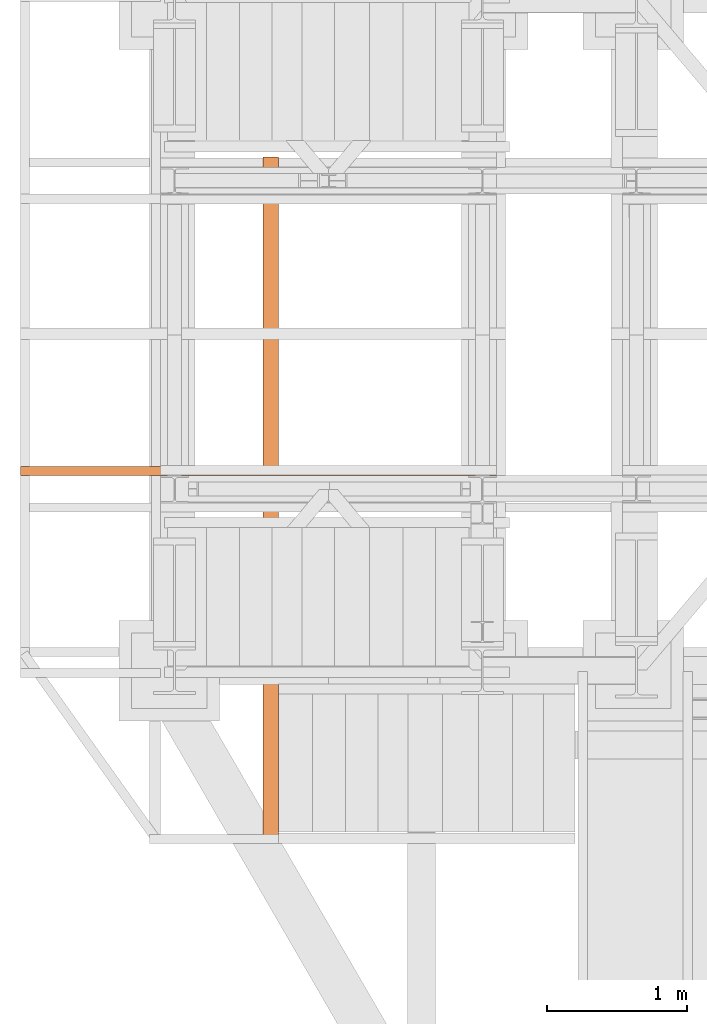
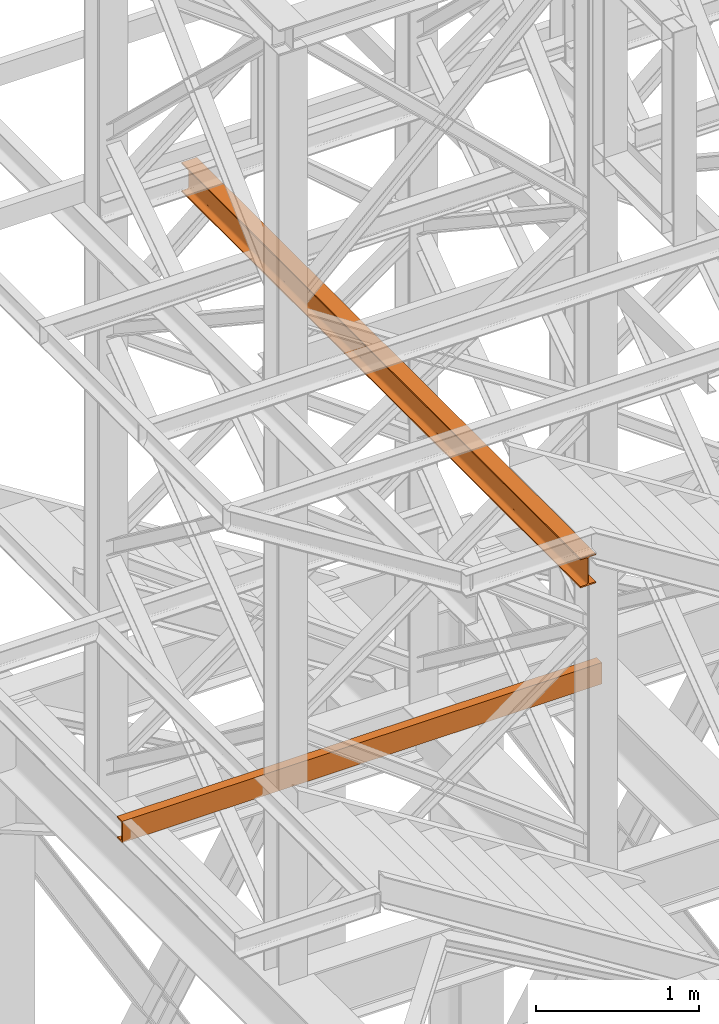
# One storey, part 84 of 208: 2 proxies.
"""IFC2X3 building model written with IfcOpenShell, lengths in millimetres."""

from ifc_helpers import new_model, entity, si_unit, converted_unit, frame, origin, origin_with_axes, place, context, subcontext, project, spatial, faceted_brep, element, save


model = new_model("IFC2X3")

# Units and contexts
model_context = context("Model", 3, precision=1e-05, world=origin())
plan_context = context("Plan", 3, precision=1e-05, world=origin())
body_context = subcontext(model_context, "Body", "Model", "MODEL_VIEW")
ifc_project = project(units=[si_unit("LENGTHUNIT", "METRE", prefix="MILLI"), converted_unit("PLANEANGLEUNIT", "DEGREE", entity("IfcPlaneAngleMeasure", 0.0174532925199433), si_unit("PLANEANGLEUNIT", "RADIAN"), dimensions=[0, 0, 0, 0, 0, 0, 0]), si_unit("AREAUNIT", "SQUARE_METRE"), si_unit("VOLUMEUNIT", "CUBIC_METRE")], contexts=[model_context, plan_context])

# Building, storey
building_placement = place(None, origin())
building = spatial("IfcBuilding", under=ifc_project, at=building_placement, CompositionType="COMPLEX")
storey_placement = place(building_placement, origin_with_axes())
storey = spatial("IfcBuildingStorey", under=building, at=storey_placement, Name="Geschoss", CompositionType="ELEMENT")

# Proxies
proxy_1_placement = place(storey_placement, frame((-4406.745032961457, -15867.5743840594, 6584.990005364416), z_axis=(0.0, 0.0, 1.0), x_axis=(1.0, 0.0, 0.0)))
element("IfcBuildingElementProxy", 1, at=proxy_1_placement, inside=storey, context=body_context, shape_type="Brep", body=[
    faceted_brep([(0.01000000000021828, 65.01000000000022, 0.01000000000021828), (3400.010002980236, 65.01000000000022, 0.01000000000021828), (3400.010002980236, 65.01000000000022, 3.132428070246533), (0.01000000000021828, 65.01000000000022, 3.132428070246533), (0.01000000000021828, 65.01000000000022, 3.132428070246533), (3400.010002980236, 65.01000000000022, 3.132428070246533), (3400.010002980236, 64.76726342282745, 4.748288908171162), (0.01000000000021828, 64.76726342282745, 4.748288908171162), (0.01000000000021828, 64.76726342282745, 4.748288908171162), (3400.010002980236, 64.76726342282745, 4.748288908171162), (3400.010002980236, 64.06053228585552, 6.221534443444398), (0.01000000000021828, 64.06053228585733, 6.221534443444398), (0.01000000000021828, 64.06053228585733, 6.221534443444398), (3400.010002980236, 64.06053228585552, 6.221534443444398), (3400.010002980236, 62.95215163846842, 7.422126703873801), (0.01000000000021828, 62.95215163847024, 7.422126703873801), (0.01000000000021828, 62.95215163847024, 7.422126703873801), (3400.010002980236, 62.95215163846842, 7.422126703873801), (3400.010002980236, 61.53995641148504, 8.244091391710754), (0.01000000000021828, 61.53995641148504, 8.244091391710754), (0.01000000000021828, 61.53995641148504, 8.244091391710754), (3400.010002980236, 61.53995641148504, 8.244091391710754), (3400.010002980236, 59.9485987225562, 8.614912102195376), (0.01000000000021828, 59.9485987225562, 8.614912102195376), (0.01000000000021828, 59.9485987225562, 8.614912102195376), (3400.010002980236, 59.9485987225562, 8.614912102195376), (3400.010002980236, 17.17267516602988, 12.0369859867169), (0.01000000000021828, 17.17267516602988, 12.0369859867169), (0.01000000000021828, 17.17267516602988, 12.0369859867169), (3400.010002980236, 17.17267516602988, 12.0369859867169), (3400.010002980236, 14.13462866898408, 12.74491643400506), (0.01000000000021828, 14.13462866898408, 12.74491643400506), (0.01000000000021828, 14.13462866898408, 12.74491643400506), (3400.010002980236, 14.13462866898408, 12.74491643400506), (3400.010002980236, 11.43861959928654, 14.31412174714933), (0.01000000000021828, 11.43861959928654, 14.31412174714933), (0.01000000000021828, 11.43861959928654, 14.31412174714933), (3400.010002980236, 11.43861959928654, 14.31412174714933), (3400.010002980236, 9.322620181546881, 16.60616151705835), (0.01000000000021828, 9.322620181546881, 16.60616151705835), (0.01000000000021828, 9.322620181546881, 16.60616151705835), (3400.010002980236, 9.322620181546881, 16.60616151705835), (3400.010002980236, 7.97340619278657, 19.41872117530875), (0.01000000000021828, 7.97340619278657, 19.41872117530875), (0.01000000000021828, 7.97340619278657, 19.41872117530875), (3400.010002980236, 7.97340619278657, 19.41872117530875), (3400.010002980236, 7.510000000000218, 22.50354641134618), (0.01000000000021828, 7.510000000000218, 22.50354641134618), (0.01000000000021828, 7.510000000000218, 22.50354641134618), (3400.010002980236, 7.510000000000218, 22.50354641134618), (3400.010002980236, 7.510000000000218, 137.5164535886524), (0.01000000000021828, 7.510000000000218, 137.5164535886524), (0.01000000000021828, 7.510000000000218, 137.5164535886524), (3400.010002980236, 7.510000000000218, 137.5164535886524), (3400.010002980236, 7.97340619278657, 140.6012788246917), (0.01000000000021828, 7.97340619278657, 140.6012788246917), (0.01000000000021828, 7.97340619278657, 140.6012788246917), (3400.010002980236, 7.97340619278657, 140.6012788246917), (3400.010002980236, 9.322620181546881, 143.4138384829403), (0.01000000000021828, 9.322620181546881, 143.4138384829403), (0.01000000000021828, 9.322620181546881, 143.4138384829403), (3400.010002980236, 9.322620181546881, 143.4138384829403), (3400.010002980236, 11.43861959928654, 145.7058782528493), (0.01000000000021828, 11.43861959928654, 145.7058782528493), (0.01000000000021828, 11.43861959928654, 145.7058782528493), (3400.010002980236, 11.43861959928654, 145.7058782528493), (3400.010002980236, 14.13462866898408, 147.2750835659936), (0.01000000000021828, 14.13462866898408, 147.2750835659936), (0.01000000000021828, 14.13462866898408, 147.2750835659936), (3400.010002980236, 14.13462866898408, 147.2750835659936), (3400.010002980236, 17.17267516602988, 147.9830140132817), (0.01000000000021828, 17.17267516602988, 147.9830140132817), (0.01000000000021828, 17.17267516602988, 147.9830140132817), (3400.010002980236, 17.17267516602988, 147.9830140132817), (3400.010002980236, 59.9485987225562, 151.4050878978032), (0.01000000000021828, 59.9485987225562, 151.4050878978032), (0.01000000000021828, 59.9485987225562, 151.4050878978032), (3400.010002980236, 59.9485987225562, 151.4050878978032), (3400.010002980236, 61.53995641148504, 151.7759086082879), (0.01000000000021828, 61.53995641148504, 151.7759086082879), (0.01000000000021828, 61.53995641148504, 151.7759086082879), (3400.010002980236, 61.53995641148504, 151.7759086082879), (3400.010002980236, 62.95215163846842, 152.5978732961248), (0.01000000000021828, 62.95215163847024, 152.5978732961248), (0.01000000000021828, 62.95215163847024, 152.5978732961248), (3400.010002980236, 62.95215163846842, 152.5978732961248), (3400.010002980236, 64.06053228585552, 153.7984655565542), (0.01000000000021828, 64.06053228585733, 153.7984655565542), (0.01000000000021828, 64.06053228585733, 153.7984655565542), (3400.010002980236, 64.06053228585552, 153.7984655565542), (3400.010002980236, 64.76726342282745, 155.2717110918275), (0.01000000000021828, 64.76726342282745, 155.2717110918275), (0.01000000000021828, 64.76726342282745, 155.2717110918275), (3400.010002980236, 64.76726342282745, 155.2717110918275), (3400.010002980236, 65.01000000000022, 156.8875719297521), (0.01000000000021828, 65.01000000000022, 156.8875719297521), (0.01000000000021828, 65.01000000000022, 156.8875719297521), (3400.010002980236, 65.01000000000022, 156.8875719297521), (3400.010002980236, 65.01000000000022, 160.0100000000002), (0.01000000000021828, 65.01000000000022, 160.0100000000002), (0.01000000000021828, 65.01000000000022, 160.0100000000002), (3400.010002980236, 65.01000000000022, 160.0100000000002), (3400.010002980236, 0.01000000000021828, 160.0100000000002), (0.01000000000021828, 0.01000000000021828, 160.0100000000002), (0.01000000000021828, 0.01000000000021828, 160.0100000000002), (3400.010002980236, 0.01000000000021828, 160.0100000000002), (3400.010002980236, 0.01000000000021828, 0.01000000000021828), (0.01000000000021828, 0.01000000000021828, 0.01000000000021828), (0.01000000000021828, 0.01000000000021828, 0.01000000000021828), (3400.010002980236, 0.01000000000021828, 0.01000000000021828), (3400.010002980236, 65.01000000000022, 0.01000000000021828), (0.01000000000021828, 65.01000000000022, 0.01000000000021828), (0.01000000000021828, 65.01000000000022, 0.01000000000021828), (0.01000000000021828, 65.01000000000022, 3.132428070246533), (0.01000000000021828, 64.76726342282745, 4.748288908171162), (0.01000000000021828, 64.06053228585733, 6.221534443444398), (0.01000000000021828, 62.95215163847024, 7.422126703873801), (0.01000000000021828, 61.53995641148504, 8.244091391710754), (0.01000000000021828, 59.9485987225562, 8.614912102195376), (0.01000000000021828, 17.17267516602988, 12.0369859867169), (0.01000000000021828, 14.13462866898408, 12.74491643400506), (0.01000000000021828, 11.43861959928654, 14.31412174714933), (0.01000000000021828, 9.322620181546881, 16.60616151705835), (0.01000000000021828, 7.97340619278657, 19.41872117530875), (0.01000000000021828, 7.510000000000218, 22.50354641134618), (0.01000000000021828, 7.510000000000218, 137.5164535886524), (0.01000000000021828, 7.97340619278657, 140.6012788246917), (0.01000000000021828, 9.322620181546881, 143.4138384829403), (0.01000000000021828, 11.43861959928654, 145.7058782528493), (0.01000000000021828, 14.13462866898408, 147.2750835659936), (0.01000000000021828, 17.17267516602988, 147.9830140132817), (0.01000000000021828, 59.9485987225562, 151.4050878978032), (0.01000000000021828, 61.53995641148504, 151.7759086082879), (0.01000000000021828, 62.95215163847024, 152.5978732961248), (0.01000000000021828, 64.06053228585733, 153.7984655565542), (0.01000000000021828, 64.76726342282745, 155.2717110918275), (0.01000000000021828, 65.01000000000022, 156.8875719297521), (0.01000000000021828, 65.01000000000022, 160.0100000000002), (0.01000000000021828, 0.01000000000021828, 160.0100000000002), (0.01000000000021828, 0.01000000000021828, 0.01000000000021828), (3400.010002980236, 65.01000000000022, 0.01000000000021828), (3400.010002980236, 0.01000000000021828, 0.01000000000021828), (3400.010002980236, 0.01000000000021828, 160.0100000000002), (3400.010002980236, 65.01000000000022, 160.0100000000002), (3400.010002980236, 65.01000000000022, 156.8875719297521), (3400.010002980236, 64.76726342282745, 155.2717110918275), (3400.010002980236, 64.06053228585552, 153.7984655565542), (3400.010002980236, 62.95215163846842, 152.5978732961248), (3400.010002980236, 61.53995641148504, 151.7759086082879), (3400.010002980236, 59.9485987225562, 151.4050878978032), (3400.010002980236, 17.17267516602988, 147.9830140132817), (3400.010002980236, 14.13462866898408, 147.2750835659936), (3400.010002980236, 11.43861959928654, 145.7058782528493), (3400.010002980236, 9.322620181546881, 143.4138384829403), (3400.010002980236, 7.97340619278657, 140.6012788246917), (3400.010002980236, 7.510000000000218, 137.5164535886524), (3400.010002980236, 7.510000000000218, 22.50354641134618), (3400.010002980236, 7.97340619278657, 19.41872117530875), (3400.010002980236, 9.322620181546881, 16.60616151705835), (3400.010002980236, 11.43861959928654, 14.31412174714933), (3400.010002980236, 14.13462866898408, 12.74491643400506), (3400.010002980236, 17.17267516602988, 12.0369859867169), (3400.010002980236, 59.9485987225562, 8.614912102195376), (3400.010002980236, 61.53995641148504, 8.244091391710754), (3400.010002980236, 62.95215163846842, 7.422126703873801), (3400.010002980236, 64.06053228585552, 6.221534443444398), (3400.010002980236, 64.76726342282745, 4.748288908171162), (3400.010002980236, 65.01000000000022, 3.132428070246533)], [[[0, 1, 2, 3]], [[4, 5, 6, 7]], [[8, 9, 10, 11]], [[12, 13, 14, 15]], [[16, 17, 18, 19]], [[20, 21, 22, 23]], [[24, 25, 26, 27]], [[28, 29, 30, 31]], [[32, 33, 34, 35]], [[36, 37, 38, 39]], [[40, 41, 42, 43]], [[44, 45, 46, 47]], [[48, 49, 50, 51]], [[52, 53, 54, 55]], [[56, 57, 58, 59]], [[60, 61, 62, 63]], [[64, 65, 66, 67]], [[68, 69, 70, 71]], [[72, 73, 74, 75]], [[76, 77, 78, 79]], [[80, 81, 82, 83]], [[84, 85, 86, 87]], [[88, 89, 90, 91]], [[92, 93, 94, 95]], [[96, 97, 98, 99]], [[100, 101, 102, 103]], [[104, 105, 106, 107]], [[108, 109, 110, 111]], [[112, 113, 114, 115, 116, 117, 118, 119, 120, 121, 122, 123, 124, 125, 126, 127, 128, 129, 130, 131, 132, 133, 134, 135, 136, 137, 138, 139]], [[140, 141, 142, 143, 144, 145, 146, 147, 148, 149, 150, 151, 152, 153, 154, 155, 156, 157, 158, 159, 160, 161, 162, 163, 164, 165, 166, 167]]], orient=[[False], [False], [False], [False], [False], [False], [False], [False], [False], [False], [False], [False], [False], [False], [False], [False], [False], [False], [False], [False], [False], [False], [False], [False], [False], [False], [False], [False], [False], [False]]),
])
proxy_2_placement = place(storey_placement, frame((-2673.970189809399, -18492.51299053056, 9479.99), z_axis=(0.0, 0.0, 1.0), x_axis=(1.0, 0.0, 0.0)))
element("IfcBuildingElementProxy", 2, at=proxy_2_placement, inside=storey, Name="3D Element", context=body_context, shape_type="Brep", body=[
    faceted_brep([(0.01000000000021828, 4900.010002980234, 9.209999809265355), (0.01000000000021828, 4900.010002980234, 0.01000000000021828), (110.0100000000002, 4900.010002980234, 0.01000000000021828), (110.0100000000002, 4900.010002980234, 9.209999809265355), (70.57913068098969, 4900.010002980234, 9.209999809265355), (66.251808693969, 4900.010002980234, 9.797362501594762), (62.90658890732811, 4900.010002980234, 11.50181071442057), (60.25181095283915, 4900.010002980234, 14.15658866890954), (58.54736274001334, 4900.010002980234, 17.50180845555042), (57.96000004768393, 4900.010002980234, 21.20999980926536), (57.96000004768393, 4900.010002980234, 198.8100001907351), (58.36892529768193, 4900.010002980234, 201.915818315525), (59.56772743354668, 4900.010002980234, 204.8099826905327), (61.47471867344575, 4900.010002980234, 207.2952815649733), (63.96001754788813, 4900.010002980234, 209.2022728048742), (66.85418192289399, 4900.010002980234, 210.4010749407371), (69.96000004768393, 4900.010002980234, 210.8100001907351), (110.0100000000002, 4900.010002980234, 210.8100001907351), (110.0100000000002, 4900.010002980234, 220.0100000000002), (0.01000000000021828, 4900.010002980234, 220.0100000000002), (0.01000000000021828, 4900.010002980234, 210.8100001907351), (40.0599999523165, 4900.010002980234, 210.8100001907351), (43.16581807710645, 4900.010002980234, 210.4010749407371), (46.05998245211413, 4900.010002980234, 209.2022728048742), (48.54528132655469, 4900.010002980234, 207.2952815649733), (50.52982171082658, 4900.010002980234, 204.6227624944386), (51.65107470232033, 4900.010002980234, 201.915818315525), (52.0599999523165, 4900.010002980234, 198.8100001907351), (52.0599999523165, 4900.010002980234, 21.20999980926536), (51.65107470232033, 4900.010002980234, 18.10418168447541), (50.45227256645558, 4900.010002980234, 15.21001730946955), (48.54528132655469, 4900.010002980234, 12.72471843502717), (46.05998245211413, 4900.010002980234, 10.81772719512628), (43.16581807710645, 4900.010002980234, 9.618925059263347), (40.0599999523165, 4900.010002980234, 9.209999809265355), (0.01000000000021828, 4900.010002980234, 0.01000000000021828), (0.01000000000021828, 4900.010002980234, 9.209999809265355), (0.01000000000021828, 0.00999999999839929, 9.209999809265355), (0.01000000000021828, 0.00999999999839929, 0.01000000000021828), (110.0100000000002, 4900.010002980234, 0.01000000000021828), (0.01000000000021828, 4900.010002980234, 0.01000000000021828), (0.01000000000021828, 0.00999999999839929, 0.01000000000021828), (110.0100000000002, 0.00999999999839929, 0.01000000000021828), (110.0100000000002, 4900.010002980234, 9.209999809265355), (110.0100000000002, 4900.010002980234, 0.01000000000021828), (110.0100000000002, 0.00999999999839929, 0.01000000000021828), (110.0100000000002, 0.00999999999839929, 9.209999809265355), (70.57913068098969, 4900.010002980234, 9.209999809265355), (110.0100000000002, 4900.010002980234, 9.209999809265355), (110.0100000000002, 0.00999999999839929, 9.209999809265355), (70.57913068098969, 0.00999999999839929, 9.209999809265355), (66.251808693969, 4900.010002980234, 9.797362501594762), (70.57913068098969, 4900.010002980234, 9.209999809265355), (70.57913068098969, 0.00999999999839929, 9.209999809265355), (66.251808693969, 0.00999999999839929, 9.797362501594762), (62.90658890732811, 4900.010002980234, 11.50181071442057), (66.251808693969, 4900.010002980234, 9.797362501594762), (66.251808693969, 0.00999999999839929, 9.797362501594762), (62.90658890732811, 0.00999999999839929, 11.50181071442057), (60.25181095283915, 4900.010002980234, 14.15658866890954), (62.90658890732811, 4900.010002980234, 11.50181071442057), (62.90658890732811, 0.00999999999839929, 11.50181071442057), (60.25181095283915, 0.00999999999839929, 14.15658866890954), (58.54736274001334, 4900.010002980234, 17.50180845555042), (60.25181095283915, 4900.010002980234, 14.15658866890954), (60.25181095283915, 0.00999999999839929, 14.15658866890954), (58.54736274001334, 0.00999999999839929, 17.50180845555042), (57.96000004768393, 4900.010002980234, 21.20999980926536), (58.54736274001334, 4900.010002980234, 17.50180845555042), (58.54736274001334, 0.00999999999839929, 17.50180845555042), (57.96000004768393, 0.00999999999839929, 21.20999980926536), (57.96000004768393, 4900.010002980234, 198.8100001907351), (57.96000004768393, 4900.010002980234, 21.20999980926536), (57.96000004768393, 0.00999999999839929, 21.20999980926536), (57.96000004768393, 0.00999999999839929, 198.8100001907351), (58.36892529768193, 4900.010002980234, 201.915818315525), (57.96000004768393, 4900.010002980234, 198.8100001907351), (57.96000004768393, 0.00999999999839929, 198.8100001907351), (58.36892529768193, 0.00999999999839929, 201.915818315525), (59.56772743354668, 4900.010002980234, 204.8099826905327), (58.36892529768193, 4900.010002980234, 201.915818315525), (58.36892529768193, 0.00999999999839929, 201.915818315525), (59.56772743354668, 0.00999999999839929, 204.8099826905327), (61.47471867344575, 4900.010002980234, 207.2952815649733), (59.56772743354668, 4900.010002980234, 204.8099826905327), (59.56772743354668, 0.00999999999839929, 204.8099826905327), (61.47471867344575, 0.00999999999839929, 207.2952815649733), (63.96001754788813, 4900.010002980234, 209.2022728048742), (61.47471867344575, 4900.010002980234, 207.2952815649733), (61.47471867344575, 0.00999999999839929, 207.2952815649733), (63.96001754788813, 0.00999999999839929, 209.2022728048742), (66.85418192289399, 4900.010002980234, 210.4010749407371), (63.96001754788813, 4900.010002980234, 209.2022728048742), (63.96001754788813, 0.00999999999839929, 209.2022728048742), (66.85418192289399, 0.00999999999839929, 210.4010749407371), (69.96000004768393, 4900.010002980234, 210.8100001907351), (66.85418192289399, 4900.010002980234, 210.4010749407371), (66.85418192289399, 0.00999999999839929, 210.4010749407371), (69.96000004768393, 0.00999999999839929, 210.8100001907351), (110.0100000000002, 4900.010002980234, 210.8100001907351), (69.96000004768393, 4900.010002980234, 210.8100001907351), (69.96000004768393, 0.00999999999839929, 210.8100001907351), (110.0100000000002, 0.00999999999839929, 210.8100001907351), (110.0100000000002, 4900.010002980234, 220.0100000000002), (110.0100000000002, 4900.010002980234, 210.8100001907351), (110.0100000000002, 0.00999999999839929, 210.8100001907351), (110.0100000000002, 0.00999999999839929, 220.0100000000002), (0.01000000000021828, 4900.010002980234, 220.0100000000002), (110.0100000000002, 4900.010002980234, 220.0100000000002), (110.0100000000002, 0.00999999999839929, 220.0100000000002), (0.01000000000021828, 0.00999999999839929, 220.0100000000002), (0.01000000000021828, 4900.010002980234, 210.8100001907351), (0.01000000000021828, 4900.010002980234, 220.0100000000002), (0.01000000000021828, 0.00999999999839929, 220.0100000000002), (0.01000000000021828, 0.00999999999839929, 210.8100001907351), (40.0599999523165, 4900.010002980234, 210.8100001907351), (0.01000000000021828, 4900.010002980234, 210.8100001907351), (0.01000000000021828, 0.00999999999839929, 210.8100001907351), (40.0599999523165, 0.00999999999839929, 210.8100001907351), (43.16581807710645, 4900.010002980234, 210.4010749407371), (40.0599999523165, 4900.010002980234, 210.8100001907351), (40.0599999523165, 0.00999999999839929, 210.8100001907351), (43.16581807710645, 0.00999999999839929, 210.4010749407371), (46.05998245211413, 4900.010002980234, 209.2022728048742), (43.16581807710645, 4900.010002980234, 210.4010749407371), (43.16581807710645, 0.00999999999839929, 210.4010749407371), (46.05998245211413, 0.00999999999839929, 209.2022728048742), (48.54528132655469, 4900.010002980234, 207.2952815649733), (46.05998245211413, 4900.010002980234, 209.2022728048742), (46.05998245211413, 0.00999999999839929, 209.2022728048742), (48.54528132655469, 0.00999999999839929, 207.2952815649733), (50.52982171082658, 4900.010002980234, 204.6227624944386), (48.54528132655469, 4900.010002980234, 207.2952815649733), (48.54528132655469, 0.00999999999839929, 207.2952815649733), (50.52982171082658, 0.00999999999839929, 204.6227624944386), (51.65107470232033, 4900.010002980234, 201.915818315525), (50.52982171082658, 4900.010002980234, 204.6227624944386), (50.52982171082658, 0.00999999999839929, 204.6227624944386), (51.65107470232033, 0.00999999999839929, 201.915818315525), (52.0599999523165, 4900.010002980234, 198.8100001907351), (51.65107470232033, 4900.010002980234, 201.915818315525), (51.65107470232033, 0.00999999999839929, 201.915818315525), (52.0599999523165, 0.00999999999839929, 198.8100001907351), (52.0599999523165, 4900.010002980234, 21.20999980926536), (52.0599999523165, 4900.010002980234, 198.8100001907351), (52.0599999523165, 0.00999999999839929, 198.8100001907351), (52.0599999523165, 0.00999999999839929, 21.20999980926536), (51.65107470232033, 4900.010002980234, 18.10418168447541), (52.0599999523165, 4900.010002980234, 21.20999980926536), (52.0599999523165, 0.00999999999839929, 21.20999980926536), (51.65107470232033, 0.00999999999839929, 18.10418168447541), (50.45227256645558, 4900.010002980234, 15.21001730946955), (51.65107470232033, 4900.010002980234, 18.10418168447541), (51.65107470232033, 0.00999999999839929, 18.10418168447541), (50.45227256645558, 0.00999999999839929, 15.21001730946955), (48.54528132655469, 4900.010002980234, 12.72471843502717), (50.45227256645558, 4900.010002980234, 15.21001730946955), (50.45227256645558, 0.00999999999839929, 15.21001730946955), (48.54528132655469, 0.00999999999839929, 12.72471843502717), (46.05998245211413, 4900.010002980234, 10.81772719512628), (48.54528132655469, 4900.010002980234, 12.72471843502717), (48.54528132655469, 0.00999999999839929, 12.72471843502717), (46.05998245211413, 0.00999999999839929, 10.81772719512628), (43.16581807710645, 4900.010002980234, 9.618925059263347), (46.05998245211413, 4900.010002980234, 10.81772719512628), (46.05998245211413, 0.00999999999839929, 10.81772719512628), (43.16581807710645, 0.00999999999839929, 9.618925059263347), (40.0599999523165, 4900.010002980234, 9.209999809265355), (43.16581807710645, 4900.010002980234, 9.618925059263347), (43.16581807710645, 0.00999999999839929, 9.618925059263347), (40.0599999523165, 0.00999999999839929, 9.209999809265355), (0.01000000000021828, 4900.010002980234, 9.209999809265355), (40.0599999523165, 4900.010002980234, 9.209999809265355), (40.0599999523165, 0.00999999999839929, 9.209999809265355), (0.01000000000021828, 0.00999999999839929, 9.209999809265355), (0.01000000000021828, 0.00999999999839929, 9.209999809265355), (40.0599999523165, 0.00999999999839929, 9.209999809265355), (43.16581807710645, 0.00999999999839929, 9.618925059263347), (46.05998245211413, 0.00999999999839929, 10.81772719512628), (48.54528132655469, 0.00999999999839929, 12.72471843502717), (50.45227256645558, 0.00999999999839929, 15.21001730946955), (51.65107470232033, 0.00999999999839929, 18.10418168447541), (52.0599999523165, 0.00999999999839929, 21.20999980926536), (52.0599999523165, 0.00999999999839929, 198.8100001907351), (51.65107470232033, 0.00999999999839929, 201.915818315525), (50.52982171082658, 0.00999999999839929, 204.6227624944386), (48.54528132655469, 0.00999999999839929, 207.2952815649733), (46.05998245211413, 0.00999999999839929, 209.2022728048742), (43.16581807710645, 0.00999999999839929, 210.4010749407371), (40.0599999523165, 0.00999999999839929, 210.8100001907351), (0.01000000000021828, 0.00999999999839929, 210.8100001907351), (0.01000000000021828, 0.00999999999839929, 220.0100000000002), (110.0100000000002, 0.00999999999839929, 220.0100000000002), (110.0100000000002, 0.00999999999839929, 210.8100001907351), (69.96000004768393, 0.00999999999839929, 210.8100001907351), (66.85418192289399, 0.00999999999839929, 210.4010749407371), (63.96001754788813, 0.00999999999839929, 209.2022728048742), (61.47471867344575, 0.00999999999839929, 207.2952815649733), (59.56772743354668, 0.00999999999839929, 204.8099826905327), (58.36892529768193, 0.00999999999839929, 201.915818315525), (57.96000004768393, 0.00999999999839929, 198.8100001907351), (57.96000004768393, 0.00999999999839929, 21.20999980926536), (58.54736274001334, 0.00999999999839929, 17.50180845555042), (60.25181095283915, 0.00999999999839929, 14.15658866890954), (62.90658890732811, 0.00999999999839929, 11.50181071442057), (66.251808693969, 0.00999999999839929, 9.797362501594762), (70.57913068098969, 0.00999999999839929, 9.209999809265355), (110.0100000000002, 0.00999999999839929, 9.209999809265355), (110.0100000000002, 0.00999999999839929, 0.01000000000021828), (0.01000000000021828, 0.00999999999839929, 0.01000000000021828)], [[[0, 1, 2, 3, 4, 5, 6, 7, 8, 9, 10, 11, 12, 13, 14, 15, 16, 17, 18, 19, 20, 21, 22, 23, 24, 25, 26, 27, 28, 29, 30, 31, 32, 33, 34]], [[35, 36, 37, 38]], [[39, 40, 41, 42]], [[43, 44, 45, 46]], [[47, 48, 49, 50]], [[51, 52, 53, 54]], [[55, 56, 57, 58]], [[59, 60, 61, 62]], [[63, 64, 65, 66]], [[67, 68, 69, 70]], [[71, 72, 73, 74]], [[75, 76, 77, 78]], [[79, 80, 81, 82]], [[83, 84, 85, 86]], [[87, 88, 89, 90]], [[91, 92, 93, 94]], [[95, 96, 97, 98]], [[99, 100, 101, 102]], [[103, 104, 105, 106]], [[107, 108, 109, 110]], [[111, 112, 113, 114]], [[115, 116, 117, 118]], [[119, 120, 121, 122]], [[123, 124, 125, 126]], [[127, 128, 129, 130]], [[131, 132, 133, 134]], [[135, 136, 137, 138]], [[139, 140, 141, 142]], [[143, 144, 145, 146]], [[147, 148, 149, 150]], [[151, 152, 153, 154]], [[155, 156, 157, 158]], [[159, 160, 161, 162]], [[163, 164, 165, 166]], [[167, 168, 169, 170]], [[171, 172, 173, 174]], [[175, 176, 177, 178, 179, 180, 181, 182, 183, 184, 185, 186, 187, 188, 189, 190, 191, 192, 193, 194, 195, 196, 197, 198, 199, 200, 201, 202, 203, 204, 205, 206, 207, 208, 209]]], orient=[[False], [False], [False], [False], [False], [False], [False], [False], [False], [False], [False], [False], [False], [False], [False], [False], [False], [False], [False], [False], [False], [False], [False], [False], [False], [False], [False], [False], [False], [False], [False], [False], [False], [False], [False], [False], [False]]),
])

save(model, "model.ifc")
